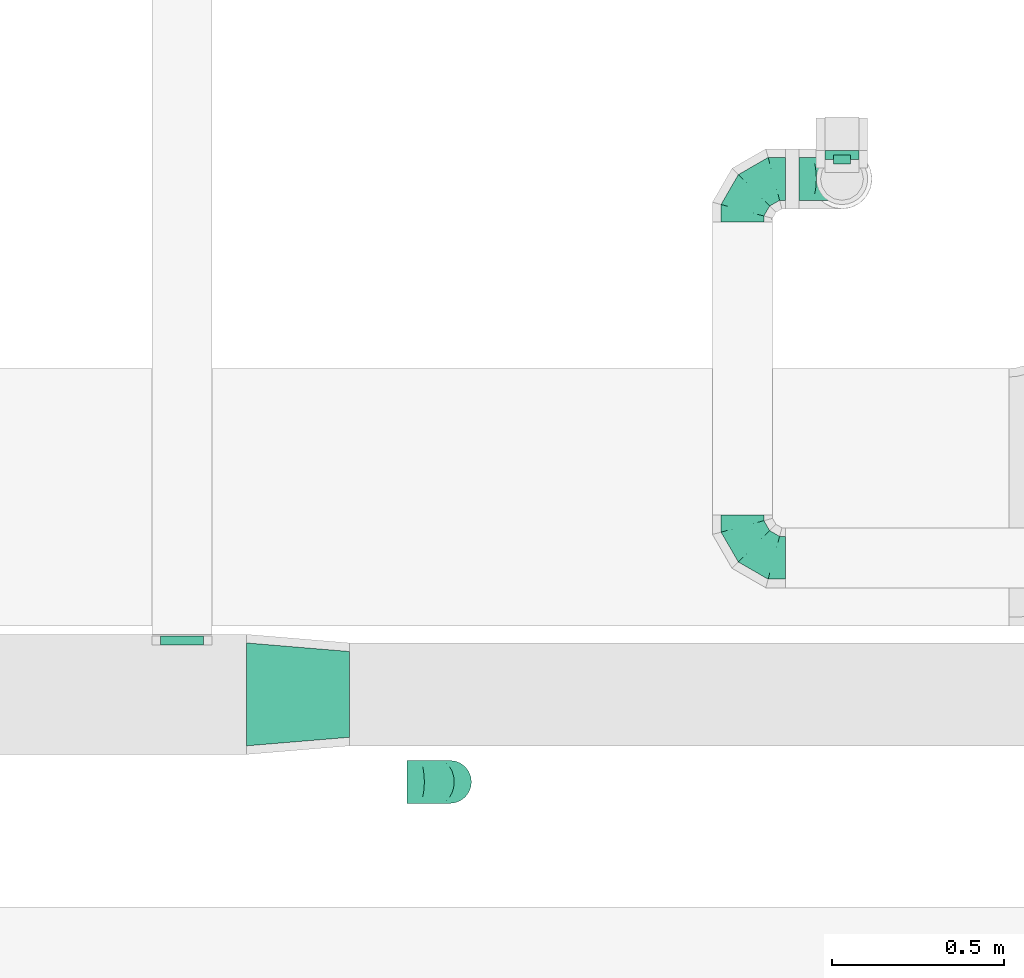
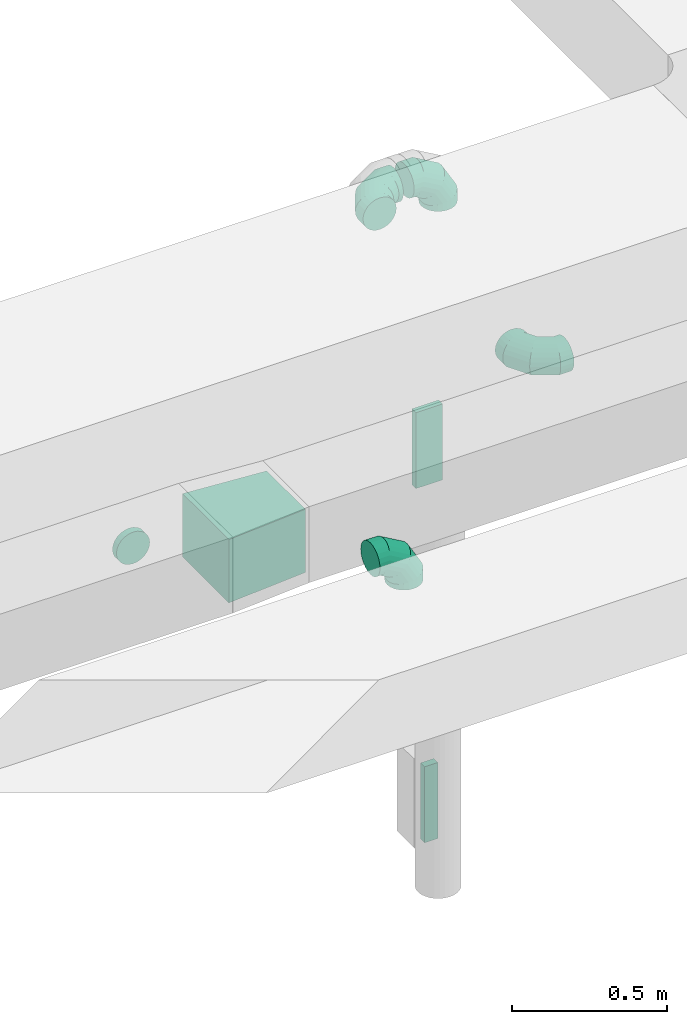
# One storey, part 45 of 97: 8 flow fittings.
"""IFC2X3 building model written with IfcOpenShell, lengths in millimetres."""

from ifc_helpers import new_model, entity, si_unit, converted_unit, derived_unit, direction, frame, origin, origin_2d_with_axis, place, context, subcontext, project, spatial, polyline, rectangle, outline, extrude, faceted_brep, source, transform, mapped, material, type_object, type_shapes, element, save


model = new_model("IFC2X3")

# Units and contexts
model_context = context("Model", 3, precision=0.01, world=origin(), true_north=direction((6.12303176911189e-17, 1.0)))
body_context = subcontext(model_context, "Body", "Model", "MODEL_VIEW")
ifc_project = project(units=[si_unit("LENGTHUNIT", "METRE", prefix="MILLI"), si_unit("AREAUNIT", "SQUARE_METRE"), si_unit("VOLUMEUNIT", "CUBIC_METRE"), converted_unit("PLANEANGLEUNIT", "DEGREE", entity("IfcRatioMeasure", 0.0174532925199433), si_unit("PLANEANGLEUNIT", "RADIAN"), dimensions=[0, 0, 0, 0, 0, 0, 0]), si_unit("MASSUNIT", "GRAM", prefix="KILO"), derived_unit("MASSDENSITYUNIT", [(si_unit("MASSUNIT", "GRAM", prefix="KILO"), 1), (si_unit("LENGTHUNIT", "METRE"), -3)]), derived_unit("MOMENTOFINERTIAUNIT", [(si_unit("LENGTHUNIT", "METRE"), 4)]), si_unit("TIMEUNIT", "SECOND"), si_unit("FREQUENCYUNIT", "HERTZ"), si_unit("THERMODYNAMICTEMPERATUREUNIT", "DEGREE_CELSIUS"), derived_unit("THERMALTRANSMITTANCEUNIT", [(si_unit("MASSUNIT", "GRAM", prefix="KILO"), 1), (si_unit("THERMODYNAMICTEMPERATUREUNIT", "KELVIN"), -1), (si_unit("TIMEUNIT", "SECOND"), -3)]), derived_unit("VOLUMETRICFLOWRATEUNIT", [(si_unit("LENGTHUNIT", "METRE"), 3), (si_unit("TIMEUNIT", "SECOND"), -1)]), derived_unit("MASSFLOWRATEUNIT", [(si_unit("MASSUNIT", "GRAM", prefix="KILO"), 1), (si_unit("TIMEUNIT", "SECOND"), -1)]), derived_unit("ROTATIONALFREQUENCYUNIT", [(si_unit("TIMEUNIT", "SECOND"), -1)]), si_unit("ELECTRICCURRENTUNIT", "AMPERE"), si_unit("ELECTRICVOLTAGEUNIT", "VOLT"), si_unit("POWERUNIT", "WATT"), si_unit("FORCEUNIT", "NEWTON", prefix="KILO"), si_unit("ILLUMINANCEUNIT", "LUX"), si_unit("LUMINOUSFLUXUNIT", "LUMEN"), si_unit("LUMINOUSINTENSITYUNIT", "CANDELA"), derived_unit("USERDEFINED", [(si_unit("MASSUNIT", "GRAM", prefix="KILO"), -1), (si_unit("LENGTHUNIT", "METRE"), -2), (si_unit("TIMEUNIT", "SECOND"), 3), (si_unit("LUMINOUSFLUXUNIT", "LUMEN"), 1)]), derived_unit("LINEARVELOCITYUNIT", [(si_unit("LENGTHUNIT", "METRE"), 1), (si_unit("TIMEUNIT", "SECOND"), -1)]), si_unit("PRESSUREUNIT", "PASCAL"), derived_unit("USERDEFINED", [(si_unit("LENGTHUNIT", "METRE"), -2), (si_unit("MASSUNIT", "GRAM", prefix="KILO"), 1), (si_unit("TIMEUNIT", "SECOND"), -2)]), derived_unit("LINEARFORCEUNIT", [(si_unit("MASSUNIT", "GRAM", prefix="KILO"), 1), (si_unit("LENGTHUNIT", "METRE"), 1), (si_unit("TIMEUNIT", "SECOND"), -2), (si_unit("LENGTHUNIT", "METRE"), -1)]), derived_unit("PLANARFORCEUNIT", [(si_unit("MASSUNIT", "GRAM", prefix="KILO"), 1), (si_unit("LENGTHUNIT", "METRE"), 1), (si_unit("TIMEUNIT", "SECOND"), -2), (si_unit("LENGTHUNIT", "METRE"), -2)])], contexts=[model_context])

# Site, building, storey
site_placement = place(None, origin())
site = spatial("IfcSite", under=ifc_project, at=site_placement, CompositionType="ELEMENT")
building_placement = place(site_placement, origin())
building = spatial("IfcBuilding", under=site, at=building_placement, CompositionType="ELEMENT")
storey_placement = place(building_placement, frame((0.0, 0.0, -4900.0)))
storey = spatial("IfcBuildingStorey", under=building, at=storey_placement, CompositionType="ELEMENT", Elevation=-4900.0)

# Flow fittings
ifc_material = material()
duct_fitting_type_1 = type_object("IfcDuctFittingType", PredefinedType="NOTDEFINED", material=ifc_material)
shared_shape_1 = source(origin(), body_context, "Body", "SweptSolid", [
    extrude(rectangle(XDim=26.0960000001476, YDim=300.0, at=origin_2d_with_axis()), frame((6.95, 0.0, -50.0)), (0.0, 0.0, 1.0), 100.0),
])
type_shapes(duct_fitting_type_1, [shared_shape_1])
flow_fitting_1_placement = place(storey_placement, frame((37323.02, 10809.97, 2850.0), z_axis=(1.0, 0.0, 0.0), x_axis=(0.0, 1.0, 0.0)))
element("IfcFlowFitting", 1, at=flow_fitting_1_placement, inside=storey, type_object=duct_fitting_type_1, material=ifc_material, context=body_context, shape_type="MappedRepresentation", body=[
    mapped(shared_shape_1, transform((0.0, 0.0, 0.0), scale=1.0)),
])
duct_fitting_type_2 = type_object("IfcDuctFittingType", PredefinedType="NOTDEFINED", material=ifc_material)
shared_shape_2 = source(origin(), body_context, "Body", "SweptSolid", [
    extrude(rectangle(XDim=26.0960000000091, YDim=300.0, at=origin_2d_with_axis()), frame((6.95, 0.0, -25.0)), (0.0, 0.0, 1.0), 50.0),
])
type_shapes(duct_fitting_type_2, [shared_shape_2])
flow_fitting_2_placement = place(storey_placement, frame((37323.02, 10797.47, 1450.0), z_axis=(1.0, 0.0, 0.0), x_axis=(0.0, 1.0, 0.0)))
element("IfcFlowFitting", 2, at=flow_fitting_2_placement, inside=storey, type_object=duct_fitting_type_2, material=ifc_material, context=body_context, shape_type="MappedRepresentation", body=[
    mapped(shared_shape_2, transform((0.0, 0.0, 0.0), scale=1.0)),
])
duct_fitting_type_3 = type_object("IfcDuctFittingType", PredefinedType="NOTDEFINED", material=ifc_material)
shared_shape_3 = source(origin(), body_context, "Body", "SweptSolid", [
    extrude(outline(polyline([(-139.1, -137.03), (161.94, -137.03), (137.03, 161.94), (-159.86, 112.11), (-139.1, -137.03)])), frame((150.0, 0.0, -125.0), z_axis=(0.0, 0.0, 1.0), x_axis=(0.996545758244879, -0.0830454798537418, 0.0)), (0.0, 0.0, 1.0), 250.0),
])
type_shapes(duct_fitting_type_3, [shared_shape_3])
flow_fitting_3_placement = place(storey_placement, frame((35887.72, 9245.01, 4000.0), z_axis=(0.0, 0.0, 1.0), x_axis=(-1.0, 0.0, 0.0)))
element("IfcFlowFitting", 3, at=flow_fitting_3_placement, inside=storey, type_object=duct_fitting_type_3, material=ifc_material, context=body_context, shape_type="MappedRepresentation", body=[
    mapped(shared_shape_3, transform((0.0, 0.0, 0.0), scale=1.0)),
])
duct_fitting_type_4 = type_object("IfcDuctFittingType", PredefinedType="NOTDEFINED", material=ifc_material)
shared_shape_4 = source(origin(), body_context, "Body", "Brep", [
    faceted_brep([(-125.0, 0.0, -62.5), (-125.0, -16.18, -60.37), (-125.0, -31.25, -54.13), (-125.0, -44.19, -44.19), (-125.0, -54.13, -31.25), (-125.0, -60.37, -16.18), (-125.0, -62.5, 0.0), (-125.0, -60.37, 16.18), (-125.0, -54.13, 31.25), (-125.0, -44.19, 44.19), (-125.0, -31.25, 54.13), (-125.0, -16.18, 60.37), (-125.0, 0.0, 62.5), (-125.0, 16.18, 60.37), (-125.0, 31.25, 54.13), (-125.0, 44.19, 44.19), (-125.0, 54.13, 31.25), (-125.0, 60.37, 16.18), (-125.0, 62.5, 0.0), (-125.0, 60.37, -16.18), (-125.0, 54.13, -31.25), (-125.0, 44.19, -44.19), (-125.0, 31.25, -54.13), (-125.0, 16.18, -60.37), (-95.84, 16.18, 60.37), (-99.88, 31.25, 54.13), (-91.51, 0.0, 62.5), (-103.35, 44.19, 44.19), (-107.68, 60.37, 16.18), (-108.25, 62.5, 0.0), (-106.01, 54.13, 31.25), (-106.01, 54.13, -31.25), (-103.35, 44.19, -44.19), (-107.68, 60.37, -16.18), (-95.84, 16.18, -60.37), (-91.51, 0.0, -62.5), (-99.88, 31.25, -54.13), (-87.17, -16.18, -60.37), (-83.13, -31.25, -54.13), (-79.66, -44.19, -44.19), (-77.0, -54.13, -31.25), (-75.33, -60.37, -16.18), (-74.76, -62.5, 0.0), (-75.33, -60.37, 16.18), (-77.0, -54.13, 31.25), (-79.66, -44.19, 44.19), (-83.13, -31.25, 54.13), (-87.17, -16.18, 60.37), (-45.34, 45.34, 60.37), (-56.37, 56.37, 54.13), (-33.49, 33.49, 62.5), (-65.85, 65.85, 44.19), (-73.12, 73.12, 31.25), (-77.69, 77.69, 16.18), (-79.25, 79.25, 0.0), (-77.69, 77.69, -16.18), (-73.12, 73.12, -31.25), (-65.85, 65.85, -44.19), (-45.34, 45.34, -60.37), (-33.49, 33.49, -62.5), (-56.37, 56.37, -54.13), (-21.65, 21.65, -60.37), (-10.62, 10.62, -54.13), (-1.14, 1.14, -44.19), (6.13, -6.13, -31.25), (10.7, -10.7, -16.18), (12.26, -12.26, 0.0), (10.7, -10.7, 16.18), (6.13, -6.13, 31.25), (-1.14, 1.14, 44.19), (-10.62, 10.62, 54.13), (-21.65, 21.65, 60.37), (-16.18, 95.84, 60.37), (-31.25, 99.88, 54.13), (0.0, 91.51, 62.5), (-44.19, 103.35, 44.19), (-54.13, 106.01, 31.25), (-60.37, 107.68, 16.18), (-62.5, 108.25, 0.0), (-60.37, 107.68, -16.18), (-54.13, 106.01, -31.25), (-44.19, 103.35, -44.19), (-16.18, 95.84, -60.37), (0.0, 91.51, -62.5), (-31.25, 99.88, -54.13), (16.18, 87.17, -60.37), (31.25, 83.13, -54.13), (44.19, 79.66, -44.19), (54.13, 77.0, -31.25), (60.37, 75.33, -16.18), (62.5, 74.76, 0.0), (60.37, 75.33, 16.18), (54.13, 77.0, 31.25), (44.19, 79.66, 44.19), (31.25, 83.13, 54.13), (16.18, 87.17, 60.37), (-16.18, 125.0, -60.37), (-31.25, 125.0, -54.13), (-44.19, 125.0, -44.19), (-54.13, 125.0, -31.25), (-60.37, 125.0, -16.18), (-62.5, 125.0, 0.0), (-60.37, 125.0, 16.18), (-54.13, 125.0, 31.25), (-44.19, 125.0, 44.19), (-31.25, 125.0, 54.13), (-16.18, 125.0, 60.37), (0.0, 125.0, 62.5), (16.18, 125.0, 60.37), (31.25, 125.0, 54.13), (44.19, 125.0, 44.19), (54.13, 125.0, 31.25), (60.37, 125.0, 16.18), (62.5, 125.0, 0.0), (60.37, 125.0, -16.18), (54.13, 125.0, -31.25), (44.19, 125.0, -44.19), (31.25, 125.0, -54.13), (16.18, 125.0, -60.37), (0.0, 125.0, -62.5)], [[[0, 1, 2, 3, 4, 5, 6, 7, 8, 9, 10, 11, 12, 13, 14, 15, 16, 17, 18, 19, 20, 21, 22, 23]], [[24, 25, 14, 13]], [[26, 24, 13, 12]], [[14, 25, 27, 15]], [[28, 29, 18, 17]], [[30, 28, 17, 16]], [[15, 27, 30, 16]], [[20, 31, 32, 21]], [[33, 31, 20, 19]], [[18, 29, 33, 19]], [[34, 35, 0, 23]], [[36, 34, 23, 22]], [[21, 32, 36, 22]], [[1, 0, 35, 37]], [[2, 1, 37, 38]], [[38, 39, 3, 2]], [[5, 4, 40, 41]], [[6, 5, 41, 42]], [[39, 40, 4, 3]], [[6, 42, 43, 7]], [[7, 43, 44, 8]], [[45, 9, 8, 44]], [[9, 45, 46, 10]], [[10, 46, 47, 11]], [[26, 12, 11, 47]], [[48, 49, 25, 24]], [[50, 48, 24, 26]], [[27, 25, 49, 51]], [[52, 53, 28, 30]], [[51, 52, 30, 27]], [[29, 28, 53, 54]], [[55, 56, 31, 33]], [[54, 55, 33, 29]], [[57, 32, 31, 56]], [[58, 59, 35, 34]], [[60, 58, 34, 36]], [[57, 60, 36, 32]], [[37, 35, 59, 61]], [[38, 37, 61, 62]], [[39, 38, 62, 63]], [[41, 40, 64, 65]], [[42, 41, 65, 66]], [[63, 64, 40, 39]], [[43, 42, 66, 67]], [[44, 43, 67, 68]], [[68, 69, 45, 44]], [[46, 45, 69, 70]], [[47, 46, 70, 71]], [[26, 47, 71, 50]], [[72, 73, 49, 48]], [[74, 72, 48, 50]], [[51, 49, 73, 75]], [[76, 77, 53, 52]], [[75, 76, 52, 51]], [[54, 53, 77, 78]], [[79, 80, 56, 55]], [[78, 79, 55, 54]], [[81, 57, 56, 80]], [[82, 83, 59, 58]], [[84, 82, 58, 60]], [[81, 84, 60, 57]], [[61, 59, 83, 85]], [[62, 61, 85, 86]], [[63, 62, 86, 87]], [[65, 64, 88, 89]], [[66, 65, 89, 90]], [[87, 88, 64, 63]], [[67, 66, 90, 91]], [[68, 67, 91, 92]], [[92, 93, 69, 68]], [[70, 69, 93, 94]], [[71, 70, 94, 95]], [[50, 71, 95, 74]], [[96, 97, 98, 99, 100, 101, 102, 103, 104, 105, 106, 107, 108, 109, 110, 111, 112, 113, 114, 115, 116, 117, 118, 119]], [[72, 74, 107, 106]], [[73, 72, 106, 105]], [[75, 73, 105, 104]], [[77, 76, 103, 102]], [[78, 77, 102, 101]], [[75, 104, 103, 76]], [[78, 101, 100, 79]], [[79, 100, 99, 80]], [[80, 99, 98, 81]], [[96, 119, 83, 82]], [[97, 96, 82, 84]], [[84, 81, 98, 97]], [[83, 119, 118, 85]], [[85, 118, 117, 86]], [[116, 87, 86, 117]], [[88, 115, 114, 89]], [[89, 114, 113, 90]], [[115, 88, 87, 116]], [[91, 90, 113, 112]], [[92, 91, 112, 111]], [[111, 110, 93, 92]], [[95, 94, 109, 108]], [[74, 95, 108, 107]], [[110, 109, 94, 93]]]),
])
type_shapes(duct_fitting_type_4, [shared_shape_4])
for number, where, z_axis, x_axis in (
    (4, (37323.02, 10747.47, 3980.0), (0.0, 1.0, 0.0), (1.0, 0.0, 0.0)),
    (5, (37033.02, 10747.47, 3980.0), (0.0, 0.0, 1.0), (-1.0, 0.0, 0.0)),
    (6, (37033.02, 9643.15, 3980.0), (0.0, 0.0, 1.0), (0.0, -1.0, 0.0)),
    (7, (36180.62, 8989.97, 3950.0), (0.0, -1.0, 0.0), (0.0, 0.0, 1.0)),
):
    element("IfcFlowFitting", number, at=place(storey_placement, frame(where, z_axis=z_axis, x_axis=x_axis)), inside=storey, type_object=duct_fitting_type_4, material=ifc_material, context=body_context, shape_type="MappedRepresentation", body=[
        mapped(shared_shape_4, transform((0.0, 0.0, 0.0), scale=1.0)),
    ])
duct_fitting_type_5 = type_object("IfcDuctFittingType", PredefinedType="NOTDEFINED", material=ifc_material)
shared_shape_5 = source(origin(), body_context, "Body", "Brep", [
    faceted_brep([(20.0, 0.0, -62.5), (20.0, 16.18, -60.37), (20.0, 31.25, -54.13), (20.0, 44.19, -44.19), (20.0, 54.13, -31.25), (20.0, 60.37, -16.18), (20.0, 62.5, 0.0), (20.0, 60.37, 16.18), (20.0, 54.13, 31.25), (20.0, 44.19, 44.19), (20.0, 31.25, 54.13), (20.0, 16.18, 60.37), (20.0, 0.0, 62.5), (20.0, -16.18, 60.37), (20.0, -31.25, 54.13), (20.0, -44.19, 44.19), (20.0, -54.13, 31.25), (20.0, -60.37, 16.18), (20.0, -62.5, 0.0), (20.0, -60.37, -16.18), (20.0, -54.13, -31.25), (20.0, -44.19, -44.19), (20.0, -31.25, -54.13), (20.0, -16.18, -60.37), (0.0, 0.0, 62.5), (-6.1, 0.0, 62.5), (-6.1, -16.18, 60.37), (0.0, -16.18, 60.37), (-6.1, -31.25, 54.13), (0.0, -31.25, 54.13), (0.0, -44.19, 44.19), (-6.1, -44.19, 44.19), (0.0, -54.13, 31.25), (-6.1, -54.13, 31.25), (-6.1, -60.37, 16.18), (0.0, -60.37, 16.18), (-6.1, -62.5, 0.0), (0.0, -62.5, 0.0), (-6.1, -60.37, -16.18), (0.0, -60.37, -16.18), (-6.1, -54.13, -31.25), (0.0, -54.13, -31.25), (0.0, -44.19, -44.19), (-6.1, -44.19, -44.19), (0.0, -31.25, -54.13), (-6.1, -31.25, -54.13), (-6.1, -16.18, -60.37), (0.0, -16.18, -60.37), (-6.1, 0.0, -62.5), (0.0, 0.0, -62.5), (-6.1, 16.18, -60.37), (0.0, 16.18, -60.37), (-6.1, 31.25, -54.13), (0.0, 31.25, -54.13), (0.0, 44.19, -44.19), (-6.1, 44.19, -44.19), (0.0, 54.13, -31.25), (-6.1, 54.13, -31.25), (-6.1, 60.37, -16.18), (0.0, 60.37, -16.18), (-6.1, 62.5, 0.0), (0.0, 62.5, 0.0), (-6.1, 60.37, 16.18), (0.0, 60.37, 16.18), (-6.1, 54.13, 31.25), (0.0, 54.13, 31.25), (0.0, 44.19, 44.19), (-6.1, 44.19, 44.19), (0.0, 31.25, 54.13), (-6.1, 31.25, 54.13), (-6.1, 16.18, 60.37), (0.0, 16.18, 60.37)], [[[0, 1, 2, 3, 4, 5, 6, 7, 8, 9, 10, 11, 12, 13, 14, 15, 16, 17, 18, 19, 20, 21, 22, 23]], [[13, 12, 24, 25, 26, 27]], [[14, 13, 27, 26, 28, 29]], [[30, 15, 14, 29, 28, 31]], [[17, 16, 32, 33, 34, 35]], [[18, 17, 35, 34, 36, 37]], [[32, 16, 15, 30, 31, 33]], [[19, 18, 37, 36, 38, 39]], [[20, 19, 39, 38, 40, 41]], [[42, 21, 20, 41, 40, 43]], [[23, 22, 44, 45, 46, 47]], [[0, 23, 47, 46, 48, 49]], [[44, 22, 21, 42, 43, 45]], [[1, 0, 49, 48, 50, 51]], [[2, 1, 51, 50, 52, 53]], [[54, 3, 2, 53, 52, 55]], [[5, 4, 56, 57, 58, 59]], [[6, 5, 59, 58, 60, 61]], [[56, 4, 3, 54, 55, 57]], [[7, 6, 61, 60, 62, 63]], [[8, 7, 63, 62, 64, 65]], [[66, 9, 8, 65, 64, 67]], [[11, 10, 68, 69, 70, 71]], [[12, 11, 71, 70, 25, 24]], [[68, 10, 9, 66, 67, 69]], [[46, 45, 43, 40, 38, 36, 34, 33, 31, 28, 26, 25, 70, 69, 67, 64, 62, 60, 58, 57, 55, 52, 50, 48]]]),
])
type_shapes(duct_fitting_type_5, [shared_shape_5])
flow_fitting_4_placement = place(storey_placement, frame((35399.64, 9395.01, 3980.0), z_axis=(0.0, 0.0, -1.0), x_axis=(0.0, 1.0, 0.0)))
element("IfcFlowFitting", 8, at=flow_fitting_4_placement, inside=storey, type_object=duct_fitting_type_5, material=ifc_material, context=body_context, shape_type="MappedRepresentation", body=[
    mapped(shared_shape_5, transform((0.0, 0.0, 0.0), scale=1.0)),
])

save(model, "model.ifc")
